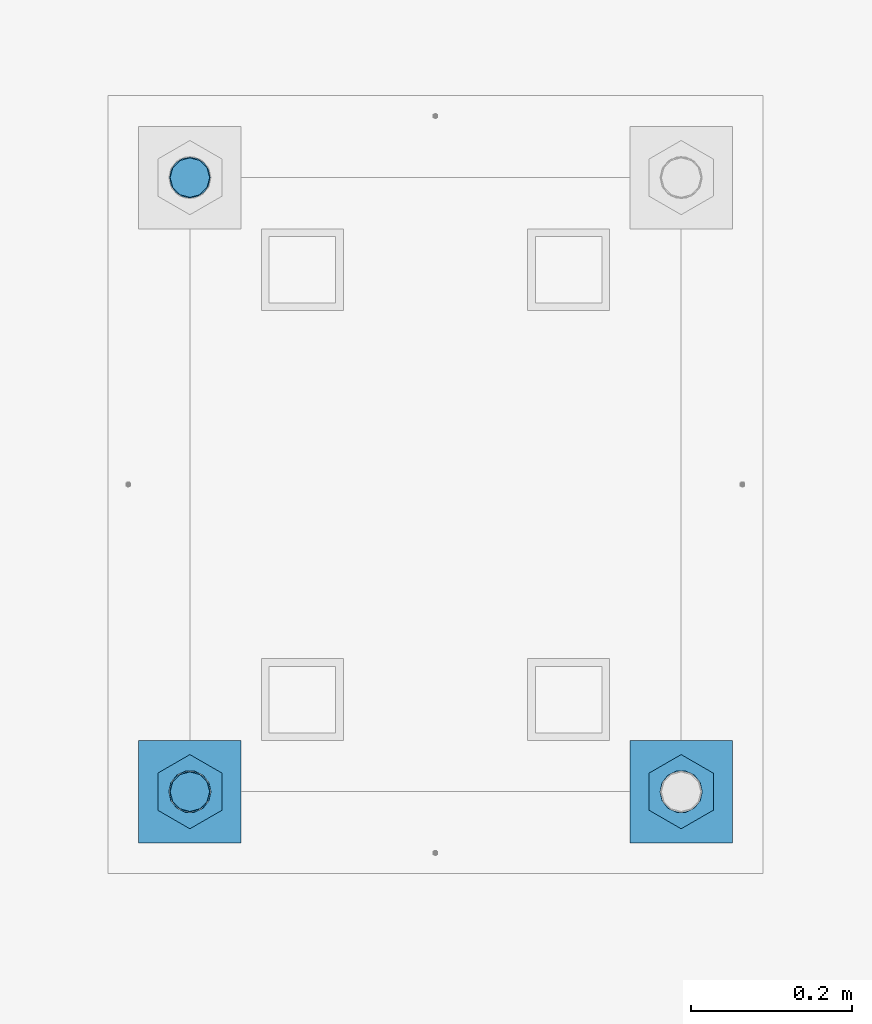
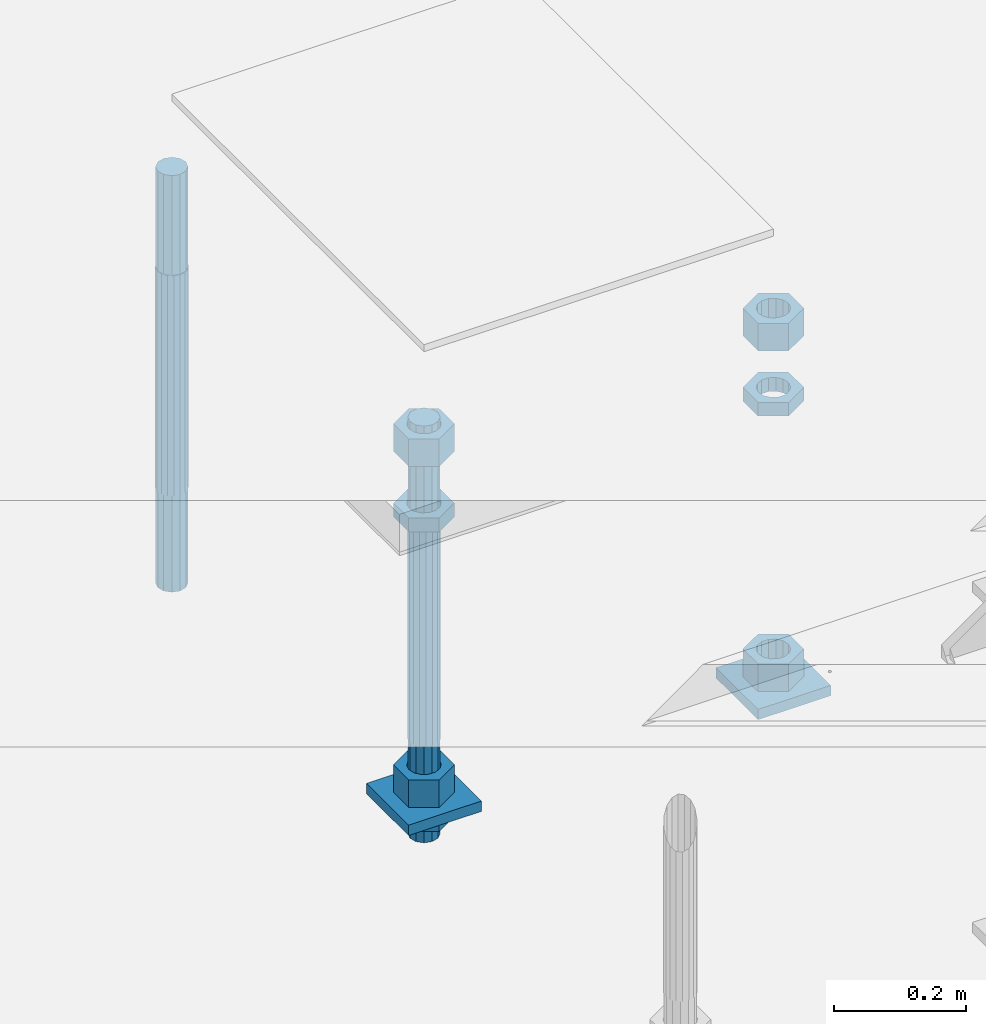
# One storey, part 2618 of 3843: 11 beams, 1 element without a shape of its own.
"""IFC2X3 building model written with IfcOpenShell, lengths in millimetres."""

from ifc_helpers import new_model, si_unit, frame, origin_with_axes, place, context, subcontext, project, spatial, faceted_brep, material, type_object, element, aggregate, save


model = new_model("IFC2X3")

# Units and contexts
model_context = context("Model", 3, precision=1e-05, world=origin_with_axes())
body_context = subcontext(model_context, "Body", "Model", "MODEL_VIEW")
ifc_project = project(units=[si_unit("LENGTHUNIT", "METRE", prefix="MILLI"), si_unit("AREAUNIT", "SQUARE_METRE"), si_unit("VOLUMEUNIT", "CUBIC_METRE"), si_unit("MASSUNIT", "GRAM", prefix="KILO"), si_unit("TIMEUNIT", "SECOND"), si_unit("PLANEANGLEUNIT", "RADIAN"), si_unit("SOLIDANGLEUNIT", "STERADIAN"), si_unit("THERMODYNAMICTEMPERATUREUNIT", "DEGREE_CELSIUS"), si_unit("LUMINOUSINTENSITYUNIT", "LUMEN")], contexts=[model_context])

# Site, building, storey
site_placement = place(None, origin_with_axes())
site = spatial("IfcSite", under=ifc_project, at=site_placement, CompositionType="ELEMENT")
building_placement = place(site_placement, origin_with_axes())
building = spatial("IfcBuilding", under=site, at=building_placement, Name="Undefined", CompositionType="ELEMENT")
storey_placement = place(building_placement, origin_with_axes())
storey = spatial("IfcBuildingStorey", under=building, at=storey_placement, Name="Undefined", CompositionType="ELEMENT", Elevation=0.0)

# Assembly, beams
assembly_placement = place(storey_placement, origin_with_axes())
assembly = element("IfcElementAssembly", 1, at=assembly_placement, inside=storey, Name="TEMPLATE", AssemblyPlace="NOTDEFINED", PredefinedType="RIGID_FRAME")
ifc_material_1 = material(Name="STEEL/A36")
beam_type_1 = type_object("IfcBeamType", PredefinedType="NOTDEFINED")
beam_1_placement = place(assembly_placement, frame((111798.099998474, 2806.70000000001, 29244.925), z_axis=(0.0, 1.0, 0.0), x_axis=(-1.0, 0.0, 0.0)))
beam_1 = element("IfcBeam", 2, at=beam_1_placement, type_object=beam_type_1, material=ifc_material_1, Name="WASHER_PLATE", context=body_context, shape_type="Brep", body=[
    faceted_brep([(0.0, 9.52500000000146, -63.5), (0.0, 9.52500000000146, 63.5), (127.0, 9.52500000000146, 63.5), (127.0, 9.52500000000146, -63.5), (0.0, -9.52500000000146, 63.5), (127.0, -9.52500000000146, 63.5), (0.0, -9.52500000000146, -63.5), (127.0, -9.52500000000146, -63.5)], [[[0, 1, 2, 3]], [[1, 4, 5, 2]], [[4, 6, 7, 5]], [[6, 0, 3, 7]], [[5, 7, 3, 2]], [[6, 4, 1, 0]]]),
])
beam_2_placement = place(assembly_placement, frame((112407.7, 2806.70000000001, 29244.925), z_axis=(0.0, 1.0, 0.0), x_axis=(-1.0, 0.0, 0.0)))
beam_2 = element("IfcBeam", 3, at=beam_2_placement, type_object=beam_type_1, material=ifc_material_1, Name="WASHER_PLATE", context=body_context, shape_type="Brep", body=[
    faceted_brep([(0.0, 9.52500000000146, -63.5), (0.0, 9.52500000000146, 63.5), (127.0, 9.52500000000146, 63.5), (127.0, 9.52500000000146, -63.5), (0.0, -9.52500000000146, 63.5), (127.0, -9.52500000000146, 63.5), (0.0, -9.52500000000146, -63.5), (127.0, -9.52500000000146, -63.5)], [[[0, 1, 2, 3]], [[1, 4, 5, 2]], [[4, 6, 7, 5]], [[6, 0, 3, 7]], [[5, 7, 3, 2]], [[6, 4, 1, 0]]]),
])
beam_type_2 = type_object("IfcBeamType", Name="2_HALF_NUT", PredefinedType="NOTDEFINED")
beam_3_placement = place(assembly_placement, frame((111734.599998474, 2806.70000000001, 29787.85), z_axis=(-1.0, 0.0, 0.0), x_axis=(0.0, 0.0, -1.0)))
beam_3 = element("IfcBeam", 4, at=beam_3_placement, type_object=beam_type_2, material=ifc_material_1, Name="NUT", ObjectType="2_HALF_NUT", context=body_context, shape_type="Brep", body=[
    faceted_brep([(0.0, -46.0369987487793, 0.0), (0.0, -23.0184993743896, -39.869213104248), (25.4000000000015, -23.0184993743896, -39.869213104248), (25.4000000000015, -46.0369987487793, 0.0), (0.0, 23.0184993743896, -39.869213104248), (25.4000000000015, 23.0184993743896, -39.869213104248), (0.0, 46.0369987487793, 0.0), (25.4000000000015, 46.0369987487793, 0.0), (0.0, 23.0184993743896, 39.869213104248), (25.4000000000015, 23.0184993743896, 39.869213104248), (0.0, -23.0184993743896, 39.869213104248), (25.4000000000015, -23.0184993743896, 39.869213104248), (0.0, 0.0, 26.1940002441406), (0.0, 11.3650617044477, 23.5999013092805), (25.4000000000015, 11.3650617044477, 23.5999013092805), (25.4000000000015, 0.0, 26.1940002441406), (0.0, 20.4791109456419, 16.3316083006721), (25.4000000000015, 20.4791109456419, 16.3316083006721), (0.0, 25.5370200498292, 5.82867859874386), (25.4000000000015, 25.5370200498292, 5.82867859874386), (0.0, 25.5370200498292, -5.82867859874386), (25.4000000000015, 25.5370200498292, -5.82867859874386), (0.0, 20.4791109456419, -16.3316083006721), (25.4000000000015, 20.4791109456419, -16.3316083006721), (0.0, 11.3650617044477, -23.5999013092805), (25.4000000000015, 11.3650617044477, -23.5999013092805), (0.0, 0.0, -26.1940002441406), (25.4000000000015, 0.0, -26.1940002441406), (0.0, -11.3650617044477, -23.5999013092805), (25.4000000000015, -11.3650617044477, -23.5999013092805), (0.0, -20.4791109456419, -16.3316083006721), (25.4000000000015, -20.4791109456419, -16.3316083006721), (0.0, -25.5370200498292, -5.82867859874386), (25.4000000000015, -25.5370200498292, -5.82867859874386), (0.0, -25.5370200498292, 5.82867859874386), (25.4000000000015, -25.5370200498292, 5.82867859874386), (0.0, -20.4791109456419, 16.3316083006721), (25.4000000000015, -20.4791109456419, 16.3316083006721), (0.0, -11.3650617044477, 23.5999013092805), (25.4000000000015, -11.3650617044477, 23.5999013092805)], [[[0, 1, 2, 3]], [[1, 4, 5, 2]], [[4, 6, 7, 5]], [[6, 8, 9, 7]], [[8, 10, 11, 9]], [[10, 0, 3, 11]], [[12, 13, 14, 15]], [[13, 16, 17, 14]], [[16, 18, 19, 17]], [[18, 20, 21, 19]], [[20, 22, 23, 21]], [[22, 24, 25, 23]], [[24, 26, 27, 25]], [[26, 28, 29, 27]], [[28, 30, 31, 29]], [[30, 32, 33, 31]], [[32, 34, 35, 33]], [[34, 36, 37, 35]], [[36, 38, 39, 37]], [[38, 12, 15, 39]], [[5, 7, 9, 11, 3, 2], [17, 19, 21, 23, 25, 27, 29, 31, 33, 35, 37, 39, 15, 14]], [[10, 8, 6, 4, 1, 0], [38, 36, 34, 32, 30, 28, 26, 24, 22, 20, 18, 16, 13, 12]]]),
])
beam_4_placement = place(assembly_placement, frame((111734.599998474, 2806.7, 29235.4), z_axis=(-1.0, 0.0, 0.0), x_axis=(0.0, 0.0, -1.0)))
beam_4 = element("IfcBeam", 5, at=beam_4_placement, type_object=beam_type_2, material=ifc_material_1, Name="NUT", ObjectType="2_HALF_NUT", context=body_context, shape_type="Brep", body=[
    faceted_brep([(0.0, -46.0369987487793, 0.0), (0.0, -23.0184993743896, -39.869213104248), (25.4000000000015, -23.0184993743896, -39.869213104248), (25.4000000000015, -46.0369987487793, 0.0), (0.0, 23.0184993743896, -39.869213104248), (25.4000000000015, 23.0184993743896, -39.869213104248), (0.0, 46.0369987487793, 0.0), (25.4000000000015, 46.0369987487793, 0.0), (0.0, 23.0184993743896, 39.869213104248), (25.4000000000015, 23.0184993743896, 39.869213104248), (0.0, -23.0184993743896, 39.869213104248), (25.4000000000015, -23.0184993743896, 39.869213104248), (0.0, 0.0, 26.1940002441406), (0.0, 11.3650617044477, 23.5999013092805), (25.4000000000015, 11.3650617044477, 23.5999013092805), (25.4000000000015, 0.0, 26.1940002441406), (0.0, 20.4791109456419, 16.3316083006721), (25.4000000000015, 20.4791109456419, 16.3316083006721), (0.0, 25.5370200498292, 5.82867859874386), (25.4000000000015, 25.5370200498292, 5.82867859874386), (0.0, 25.5370200498292, -5.82867859874386), (25.4000000000015, 25.5370200498292, -5.82867859874386), (0.0, 20.4791109456419, -16.3316083006721), (25.4000000000015, 20.4791109456419, -16.3316083006721), (0.0, 11.3650617044477, -23.5999013092805), (25.4000000000015, 11.3650617044477, -23.5999013092805), (0.0, 0.0, -26.1940002441406), (25.4000000000015, 0.0, -26.1940002441406), (0.0, -11.3650617044477, -23.5999013092805), (25.4000000000015, -11.3650617044477, -23.5999013092805), (0.0, -20.4791109456419, -16.3316083006721), (25.4000000000015, -20.4791109456419, -16.3316083006721), (0.0, -25.5370200498292, -5.82867859874386), (25.4000000000015, -25.5370200498292, -5.82867859874386), (0.0, -25.5370200498292, 5.82867859874386), (25.4000000000015, -25.5370200498292, 5.82867859874386), (0.0, -20.4791109456419, 16.3316083006721), (25.4000000000015, -20.4791109456419, 16.3316083006721), (0.0, -11.3650617044477, 23.5999013092805), (25.4000000000015, -11.3650617044477, 23.5999013092805)], [[[0, 1, 2, 3]], [[1, 4, 5, 2]], [[4, 6, 7, 5]], [[6, 8, 9, 7]], [[8, 10, 11, 9]], [[10, 0, 3, 11]], [[12, 13, 14, 15]], [[13, 16, 17, 14]], [[16, 18, 19, 17]], [[18, 20, 21, 19]], [[20, 22, 23, 21]], [[22, 24, 25, 23]], [[24, 26, 27, 25]], [[26, 28, 29, 27]], [[28, 30, 31, 29]], [[30, 32, 33, 31]], [[32, 34, 35, 33]], [[34, 36, 37, 35]], [[36, 38, 39, 37]], [[38, 12, 15, 39]], [[5, 7, 9, 11, 3, 2], [17, 19, 21, 23, 25, 27, 29, 31, 33, 35, 37, 39, 15, 14]], [[10, 8, 6, 4, 1, 0], [38, 36, 34, 32, 30, 28, 26, 24, 22, 20, 18, 16, 13, 12]]]),
])
beam_5_placement = place(assembly_placement, frame((112344.2, 2806.70000000001, 29787.85), z_axis=(-1.0, 0.0, 0.0), x_axis=(0.0, 0.0, -1.0)))
beam_5 = element("IfcBeam", 6, at=beam_5_placement, type_object=beam_type_2, material=ifc_material_1, Name="NUT", ObjectType="2_HALF_NUT", context=body_context, shape_type="Brep", body=[
    faceted_brep([(0.0, -46.0369987487793, 0.0), (0.0, -23.0184993743896, -39.869213104248), (25.4000000000015, -23.0184993743896, -39.869213104248), (25.4000000000015, -46.0369987487793, 0.0), (0.0, 23.0184993743896, -39.869213104248), (25.4000000000015, 23.0184993743896, -39.869213104248), (0.0, 46.0369987487793, 0.0), (25.4000000000015, 46.0369987487793, 0.0), (0.0, 23.0184993743896, 39.869213104248), (25.4000000000015, 23.0184993743896, 39.869213104248), (0.0, -23.0184993743896, 39.869213104248), (25.4000000000015, -23.0184993743896, 39.869213104248), (0.0, 0.0, 26.1940002441406), (0.0, 11.3650617044477, 23.5999013092805), (25.4000000000015, 11.3650617044477, 23.5999013092805), (25.4000000000015, 0.0, 26.1940002441406), (0.0, 20.4791109456419, 16.3316083006721), (25.4000000000015, 20.4791109456419, 16.3316083006721), (0.0, 25.5370200498292, 5.82867859874386), (25.4000000000015, 25.5370200498292, 5.82867859874386), (0.0, 25.5370200498292, -5.82867859874386), (25.4000000000015, 25.5370200498292, -5.82867859874386), (0.0, 20.4791109456419, -16.3316083006721), (25.4000000000015, 20.4791109456419, -16.3316083006721), (0.0, 11.3650617044477, -23.5999013092805), (25.4000000000015, 11.3650617044477, -23.5999013092805), (0.0, 0.0, -26.1940002441406), (25.4000000000015, 0.0, -26.1940002441406), (0.0, -11.3650617044477, -23.5999013092805), (25.4000000000015, -11.3650617044477, -23.5999013092805), (0.0, -20.4791109456419, -16.3316083006721), (25.4000000000015, -20.4791109456419, -16.3316083006721), (0.0, -25.5370200498292, -5.82867859874386), (25.4000000000015, -25.5370200498292, -5.82867859874386), (0.0, -25.5370200498292, 5.82867859874386), (25.4000000000015, -25.5370200498292, 5.82867859874386), (0.0, -20.4791109456419, 16.3316083006721), (25.4000000000015, -20.4791109456419, 16.3316083006721), (0.0, -11.3650617044477, 23.5999013092805), (25.4000000000015, -11.3650617044477, 23.5999013092805)], [[[0, 1, 2, 3]], [[1, 4, 5, 2]], [[4, 6, 7, 5]], [[6, 8, 9, 7]], [[8, 10, 11, 9]], [[10, 0, 3, 11]], [[12, 13, 14, 15]], [[13, 16, 17, 14]], [[16, 18, 19, 17]], [[18, 20, 21, 19]], [[20, 22, 23, 21]], [[22, 24, 25, 23]], [[24, 26, 27, 25]], [[26, 28, 29, 27]], [[28, 30, 31, 29]], [[30, 32, 33, 31]], [[32, 34, 35, 33]], [[34, 36, 37, 35]], [[36, 38, 39, 37]], [[38, 12, 15, 39]], [[5, 7, 9, 11, 3, 2], [17, 19, 21, 23, 25, 27, 29, 31, 33, 35, 37, 39, 15, 14]], [[10, 8, 6, 4, 1, 0], [38, 36, 34, 32, 30, 28, 26, 24, 22, 20, 18, 16, 13, 12]]]),
])
beam_type_3 = type_object("IfcBeamType", Name="2_HEAVY_HEX_NUT", PredefinedType="NOTDEFINED")
beam_6_placement = place(assembly_placement, frame((111734.599998474, 2806.70000000001, 29933.9), z_axis=(-1.0, 0.0, 0.0), x_axis=(0.0, 0.0, -1.0)))
beam_6 = element("IfcBeam", 7, at=beam_6_placement, type_object=beam_type_3, material=ifc_material_1, Name="NUT", ObjectType="2_HEAVY_HEX_NUT", context=body_context, shape_type="Brep", body=[
    faceted_brep([(0.0, -46.0369987487793, 0.0), (0.0, -23.0184993743896, -39.869213104248), (50.7999999999993, -23.0184993743896, -39.869213104248), (50.7999999999993, -46.0369987487793, 0.0), (0.0, 23.0184993743896, -39.869213104248), (50.7999999999993, 23.0184993743896, -39.869213104248), (0.0, 46.0369987487793, 0.0), (50.7999999999993, 46.0369987487793, 0.0), (0.0, 23.0184993743896, 39.869213104248), (50.7999999999993, 23.0184993743896, 39.869213104248), (0.0, -23.0184993743896, 39.869213104248), (50.7999999999993, -23.0184993743896, 39.869213104248), (0.0, 0.0, 26.1940002441406), (0.0, 11.3650617044477, 23.5999013092805), (50.7999999999993, 11.3650617044477, 23.5999013092805), (50.7999999999993, 0.0, 26.1940002441406), (0.0, 20.4791109456419, 16.3316083006721), (50.7999999999993, 20.4791109456419, 16.3316083006721), (0.0, 25.5370200498292, 5.82867859874386), (50.7999999999993, 25.5370200498292, 5.82867859874386), (0.0, 25.5370200498292, -5.82867859874386), (50.7999999999993, 25.5370200498292, -5.82867859874386), (0.0, 20.4791109456419, -16.3316083006721), (50.7999999999993, 20.4791109456419, -16.3316083006721), (0.0, 11.3650617044477, -23.5999013092805), (50.7999999999993, 11.3650617044477, -23.5999013092805), (0.0, 0.0, -26.1940002441406), (50.7999999999993, 0.0, -26.1940002441406), (0.0, -11.3650617044477, -23.5999013092805), (50.7999999999993, -11.3650617044477, -23.5999013092805), (0.0, -20.4791109456419, -16.3316083006721), (50.7999999999993, -20.4791109456419, -16.3316083006721), (0.0, -25.5370200498292, -5.82867859874386), (50.7999999999993, -25.5370200498292, -5.82867859874386), (0.0, -25.5370200498292, 5.82867859874386), (50.7999999999993, -25.5370200498292, 5.82867859874386), (0.0, -20.4791109456419, 16.3316083006721), (50.7999999999993, -20.4791109456419, 16.3316083006721), (0.0, -11.3650617044477, 23.5999013092805), (50.7999999999993, -11.3650617044477, 23.5999013092805)], [[[0, 1, 2, 3]], [[1, 4, 5, 2]], [[4, 6, 7, 5]], [[6, 8, 9, 7]], [[8, 10, 11, 9]], [[10, 0, 3, 11]], [[12, 13, 14, 15]], [[13, 16, 17, 14]], [[16, 18, 19, 17]], [[18, 20, 21, 19]], [[20, 22, 23, 21]], [[22, 24, 25, 23]], [[24, 26, 27, 25]], [[26, 28, 29, 27]], [[28, 30, 31, 29]], [[30, 32, 33, 31]], [[32, 34, 35, 33]], [[34, 36, 37, 35]], [[36, 38, 39, 37]], [[38, 12, 15, 39]], [[5, 7, 9, 11, 3, 2], [17, 19, 21, 23, 25, 27, 29, 31, 33, 35, 37, 39, 15, 14]], [[10, 8, 6, 4, 1, 0], [38, 36, 34, 32, 30, 28, 26, 24, 22, 20, 18, 16, 13, 12]]]),
])
beam_7_placement = place(assembly_placement, frame((111734.599998474, 2806.70000000001, 29305.25), z_axis=(-1.0, 0.0, 0.0), x_axis=(0.0, 0.0, -1.0)))
beam_7 = element("IfcBeam", 8, at=beam_7_placement, type_object=beam_type_3, material=ifc_material_1, Name="NUT", ObjectType="2_HEAVY_HEX_NUT", context=body_context, shape_type="Brep", body=[
    faceted_brep([(0.0, -46.0369987487793, 0.0), (0.0, -23.0184993743896, -39.869213104248), (50.7999999999993, -23.0184993743896, -39.869213104248), (50.7999999999993, -46.0369987487793, 0.0), (0.0, 23.0184993743896, -39.869213104248), (50.7999999999993, 23.0184993743896, -39.869213104248), (0.0, 46.0369987487793, 0.0), (50.7999999999993, 46.0369987487793, 0.0), (0.0, 23.0184993743896, 39.869213104248), (50.7999999999993, 23.0184993743896, 39.869213104248), (0.0, -23.0184993743896, 39.869213104248), (50.7999999999993, -23.0184993743896, 39.869213104248), (0.0, 0.0, 26.1940002441406), (0.0, 11.3650617044477, 23.5999013092805), (50.7999999999993, 11.3650617044477, 23.5999013092805), (50.7999999999993, 0.0, 26.1940002441406), (0.0, 20.4791109456419, 16.3316083006721), (50.7999999999993, 20.4791109456419, 16.3316083006721), (0.0, 25.5370200498292, 5.82867859874386), (50.7999999999993, 25.5370200498292, 5.82867859874386), (0.0, 25.5370200498292, -5.82867859874386), (50.7999999999993, 25.5370200498292, -5.82867859874386), (0.0, 20.4791109456419, -16.3316083006721), (50.7999999999993, 20.4791109456419, -16.3316083006721), (0.0, 11.3650617044477, -23.5999013092805), (50.7999999999993, 11.3650617044477, -23.5999013092805), (0.0, 0.0, -26.1940002441406), (50.7999999999993, 0.0, -26.1940002441406), (0.0, -11.3650617044477, -23.5999013092805), (50.7999999999993, -11.3650617044477, -23.5999013092805), (0.0, -20.4791109456419, -16.3316083006721), (50.7999999999993, -20.4791109456419, -16.3316083006721), (0.0, -25.5370200498292, -5.82867859874386), (50.7999999999993, -25.5370200498292, -5.82867859874386), (0.0, -25.5370200498292, 5.82867859874386), (50.7999999999993, -25.5370200498292, 5.82867859874386), (0.0, -20.4791109456419, 16.3316083006721), (50.7999999999993, -20.4791109456419, 16.3316083006721), (0.0, -11.3650617044477, 23.5999013092805), (50.7999999999993, -11.3650617044477, 23.5999013092805)], [[[0, 1, 2, 3]], [[1, 4, 5, 2]], [[4, 6, 7, 5]], [[6, 8, 9, 7]], [[8, 10, 11, 9]], [[10, 0, 3, 11]], [[12, 13, 14, 15]], [[13, 16, 17, 14]], [[16, 18, 19, 17]], [[18, 20, 21, 19]], [[20, 22, 23, 21]], [[22, 24, 25, 23]], [[24, 26, 27, 25]], [[26, 28, 29, 27]], [[28, 30, 31, 29]], [[30, 32, 33, 31]], [[32, 34, 35, 33]], [[34, 36, 37, 35]], [[36, 38, 39, 37]], [[38, 12, 15, 39]], [[5, 7, 9, 11, 3, 2], [17, 19, 21, 23, 25, 27, 29, 31, 33, 35, 37, 39, 15, 14]], [[10, 8, 6, 4, 1, 0], [38, 36, 34, 32, 30, 28, 26, 24, 22, 20, 18, 16, 13, 12]]]),
])
beam_8_placement = place(assembly_placement, frame((112344.2, 2806.70000000001, 29933.9), z_axis=(-1.0, 0.0, 0.0), x_axis=(0.0, 0.0, -1.0)))
beam_8 = element("IfcBeam", 9, at=beam_8_placement, type_object=beam_type_3, material=ifc_material_1, Name="NUT", ObjectType="2_HEAVY_HEX_NUT", context=body_context, shape_type="Brep", body=[
    faceted_brep([(0.0, -46.0369987487793, 0.0), (0.0, -23.0184993743896, -39.869213104248), (50.7999999999993, -23.0184993743896, -39.869213104248), (50.7999999999993, -46.0369987487793, 0.0), (0.0, 23.0184993743896, -39.869213104248), (50.7999999999993, 23.0184993743896, -39.869213104248), (0.0, 46.0369987487793, 0.0), (50.7999999999993, 46.0369987487793, 0.0), (0.0, 23.0184993743896, 39.869213104248), (50.7999999999993, 23.0184993743896, 39.869213104248), (0.0, -23.0184993743896, 39.869213104248), (50.7999999999993, -23.0184993743896, 39.869213104248), (0.0, 0.0, 26.1940002441406), (0.0, 11.3650617044477, 23.5999013092805), (50.7999999999993, 11.3650617044477, 23.5999013092805), (50.7999999999993, 0.0, 26.1940002441406), (0.0, 20.4791109456419, 16.3316083006721), (50.7999999999993, 20.4791109456419, 16.3316083006721), (0.0, 25.5370200498292, 5.82867859874386), (50.7999999999993, 25.5370200498292, 5.82867859874386), (0.0, 25.5370200498292, -5.82867859874386), (50.7999999999993, 25.5370200498292, -5.82867859874386), (0.0, 20.4791109456419, -16.3316083006721), (50.7999999999993, 20.4791109456419, -16.3316083006721), (0.0, 11.3650617044477, -23.5999013092805), (50.7999999999993, 11.3650617044477, -23.5999013092805), (0.0, 0.0, -26.1940002441406), (50.7999999999993, 0.0, -26.1940002441406), (0.0, -11.3650617044477, -23.5999013092805), (50.7999999999993, -11.3650617044477, -23.5999013092805), (0.0, -20.4791109456419, -16.3316083006721), (50.7999999999993, -20.4791109456419, -16.3316083006721), (0.0, -25.5370200498292, -5.82867859874386), (50.7999999999993, -25.5370200498292, -5.82867859874386), (0.0, -25.5370200498292, 5.82867859874386), (50.7999999999993, -25.5370200498292, 5.82867859874386), (0.0, -20.4791109456419, 16.3316083006721), (50.7999999999993, -20.4791109456419, 16.3316083006721), (0.0, -11.3650617044477, 23.5999013092805), (50.7999999999993, -11.3650617044477, 23.5999013092805)], [[[0, 1, 2, 3]], [[1, 4, 5, 2]], [[4, 6, 7, 5]], [[6, 8, 9, 7]], [[8, 10, 11, 9]], [[10, 0, 3, 11]], [[12, 13, 14, 15]], [[13, 16, 17, 14]], [[16, 18, 19, 17]], [[18, 20, 21, 19]], [[20, 22, 23, 21]], [[22, 24, 25, 23]], [[24, 26, 27, 25]], [[26, 28, 29, 27]], [[28, 30, 31, 29]], [[30, 32, 33, 31]], [[32, 34, 35, 33]], [[34, 36, 37, 35]], [[36, 38, 39, 37]], [[38, 12, 15, 39]], [[5, 7, 9, 11, 3, 2], [17, 19, 21, 23, 25, 27, 29, 31, 33, 35, 37, 39, 15, 14]], [[10, 8, 6, 4, 1, 0], [38, 36, 34, 32, 30, 28, 26, 24, 22, 20, 18, 16, 13, 12]]]),
])
beam_9_placement = place(assembly_placement, frame((112344.2, 2806.70000000001, 29305.25), z_axis=(-1.0, 0.0, 0.0), x_axis=(0.0, 0.0, -1.0)))
beam_9 = element("IfcBeam", 10, at=beam_9_placement, type_object=beam_type_3, material=ifc_material_1, Name="NUT", ObjectType="2_HEAVY_HEX_NUT", context=body_context, shape_type="Brep", body=[
    faceted_brep([(0.0, -46.0369987487793, 0.0), (0.0, -23.0184993743896, -39.869213104248), (50.7999999999993, -23.0184993743896, -39.869213104248), (50.7999999999993, -46.0369987487793, 0.0), (0.0, 23.0184993743896, -39.869213104248), (50.7999999999993, 23.0184993743896, -39.869213104248), (0.0, 46.0369987487793, 0.0), (50.7999999999993, 46.0369987487793, 0.0), (0.0, 23.0184993743896, 39.869213104248), (50.7999999999993, 23.0184993743896, 39.869213104248), (0.0, -23.0184993743896, 39.869213104248), (50.7999999999993, -23.0184993743896, 39.869213104248), (0.0, 0.0, 26.1940002441406), (0.0, 11.3650617044477, 23.5999013092805), (50.7999999999993, 11.3650617044477, 23.5999013092805), (50.7999999999993, 0.0, 26.1940002441406), (0.0, 20.4791109456419, 16.3316083006721), (50.7999999999993, 20.4791109456419, 16.3316083006721), (0.0, 25.5370200498292, 5.82867859874386), (50.7999999999993, 25.5370200498292, 5.82867859874386), (0.0, 25.5370200498292, -5.82867859874386), (50.7999999999993, 25.5370200498292, -5.82867859874386), (0.0, 20.4791109456419, -16.3316083006721), (50.7999999999993, 20.4791109456419, -16.3316083006721), (0.0, 11.3650617044477, -23.5999013092805), (50.7999999999993, 11.3650617044477, -23.5999013092805), (0.0, 0.0, -26.1940002441406), (50.7999999999993, 0.0, -26.1940002441406), (0.0, -11.3650617044477, -23.5999013092805), (50.7999999999993, -11.3650617044477, -23.5999013092805), (0.0, -20.4791109456419, -16.3316083006721), (50.7999999999993, -20.4791109456419, -16.3316083006721), (0.0, -25.5370200498292, -5.82867859874386), (50.7999999999993, -25.5370200498292, -5.82867859874386), (0.0, -25.5370200498292, 5.82867859874386), (50.7999999999993, -25.5370200498292, 5.82867859874386), (0.0, -20.4791109456419, 16.3316083006721), (50.7999999999993, -20.4791109456419, 16.3316083006721), (0.0, -11.3650617044477, 23.5999013092805), (50.7999999999993, -11.3650617044477, 23.5999013092805)], [[[0, 1, 2, 3]], [[1, 4, 5, 2]], [[4, 6, 7, 5]], [[6, 8, 9, 7]], [[8, 10, 11, 9]], [[10, 0, 3, 11]], [[12, 13, 14, 15]], [[13, 16, 17, 14]], [[16, 18, 19, 17]], [[18, 20, 21, 19]], [[20, 22, 23, 21]], [[22, 24, 25, 23]], [[24, 26, 27, 25]], [[26, 28, 29, 27]], [[28, 30, 31, 29]], [[30, 32, 33, 31]], [[32, 34, 35, 33]], [[34, 36, 37, 35]], [[36, 38, 39, 37]], [[38, 12, 15, 39]], [[5, 7, 9, 11, 3, 2], [17, 19, 21, 23, 25, 27, 29, 31, 33, 35, 37, 39, 15, 14]], [[10, 8, 6, 4, 1, 0], [38, 36, 34, 32, 30, 28, 26, 24, 22, 20, 18, 16, 13, 12]]]),
])
ifc_material_2 = material()
beam_type_4 = type_object("IfcBeamType", PredefinedType="NOTDEFINED")
beam_10_placement = place(assembly_placement, frame((111734.599998474, 3568.70000000001, 29762.45), z_axis=(-1.0, 0.0, 0.0), x_axis=(0.0, 0.0, -1.0)))
beam_10 = element("IfcBeam", 11, at=beam_10_placement, type_object=beam_type_4, material=ifc_material_2, Name="ANCHOR_ROD", context=body_context, shape_type="Brep", body=[
    faceted_brep([(-184.150000000001, -21.217622392709, 12.25), (-184.150000000001, -12.2499999999854, 21.2176223927163), (-184.150000000001, 1.45519152283669e-11, 24.5), (-184.150000000001, 12.2500000000146, 21.2176223927163), (-184.150000000001, 21.2176223927381, 12.25), (-184.150000000001, 24.5000000000146, 0.0), (-184.150000000001, 21.2176223927381, -12.25), (-184.150000000001, 12.2500000000146, -21.2176223927163), (-184.150000000001, 1.45519152283669e-11, -24.5), (-184.150000000001, -12.2499999999854, -21.2176223927163), (-184.150000000001, -21.217622392709, -12.25), (-184.150000000001, -24.4999999999854, 0.0), (0.0, 24.5000000000146, 0.0), (0.0, 21.2176223927381, -12.25), (0.0, 12.2500000000146, -21.2176223927163), (0.0, 1.45519152283669e-11, -24.5), (0.0, -12.2499999999854, -21.2176223927163), (0.0, -21.217622392709, -12.25), (0.0, -24.4999999999854, 0.0), (0.0, -21.217622392709, 12.25), (0.0, -12.2499999999854, 21.2176223927163), (0.0, 1.45519152283669e-11, 24.5), (0.0, 12.2500000000146, 21.2176223927163), (0.0, 21.2176223927381, 12.25), (0.0, -23.4665401257807, 9.72015918207035), (0.0, -17.9605122421344, 17.9605122421417), (0.0, -9.72015918207762, 23.466540125788), (0.0, 0.0, 25.4000000000015), (0.0, 9.72015918207762, 23.466540125788), (0.0, 17.9605122421344, 17.9605122421417), (0.0, 23.4665401257807, 9.72015918207035), (0.0, 25.3999996185303, 0.0), (0.0, 23.4665401257807, -9.72015918207035), (0.0, 17.9605122421344, -17.9605122421417), (0.0, 9.72015918207762, -23.466540125788), (0.0, 0.0, -25.4000000000015), (0.0, -9.72015918207762, -23.466540125788), (0.0, -17.9605122421344, -17.9605122421417), (0.0, -23.4665401257807, -9.72015918207035), (0.0, -25.3999996185303, 0.0), (406.399999999998, -25.3999999999942, 0.0), (406.399999999998, -23.4665401257807, 9.72015918207035), (406.399999999998, -17.9605122421344, 17.9605122421417), (406.399999999998, -9.72015918207762, 23.466540125788), (406.399999999998, 0.0, 25.4000000000015), (406.399999999998, 9.72015918207762, 23.466540125788), (406.399999999998, 17.9605122421344, 17.9605122421417), (406.399999999998, 23.4665401257807, 9.72015918207035), (406.399999999998, 25.3999999999942, 0.0), (406.399999999998, 23.4665401257807, -9.72015918207035), (406.399999999998, 17.9605122421344, -17.9605122421417), (406.399999999998, 9.72015918207762, -23.466540125788), (406.399999999998, 0.0, -25.4000000000015), (406.399999999998, -9.72015918207762, -23.466540125788), (406.399999999998, -17.9605122421344, -17.9605122421417), (406.399999999998, -23.4665401257807, -9.72015918207035), (406.399999999998, -12.2499999999854, 21.2176223927163), (406.399999999998, 1.45519152283669e-11, 24.5), (406.399999999998, 12.2500000000146, 21.2176223927163), (406.399999999998, 21.2176223927381, 12.25), (406.399999999998, 24.5000000000146, 0.0), (406.399999999998, 21.2176223927381, -12.25), (406.399999999998, 12.2500000000146, -21.2176223927163), (406.399999999998, 1.45519152283669e-11, -24.5), (406.399999999998, -12.2499999999854, -21.2176223927163), (406.399999999998, -21.217622392709, -12.25), (406.399999999998, -24.4999999999854, 0.0), (406.399999999998, -21.217622392709, 12.25), (584.200000000001, -12.2499999999854, -21.2176223927163), (584.200000000001, 1.45519152283669e-11, -24.5), (584.200000000001, 12.2500000000146, -21.2176223927163), (584.200000000001, 21.2176223927381, -12.25), (584.200000000001, 24.5000000000146, 0.0), (584.200000000001, 21.2176223927381, 12.25), (584.200000000001, 12.2500000000146, 21.2176223927163), (584.200000000001, 1.45519152283669e-11, 24.5), (584.200000000001, -12.2499999999854, 21.2176223927163), (584.200000000001, -21.217622392709, 12.25), (584.200000000001, -24.4999999999854, 0.0), (584.200000000001, -21.217622392709, -12.25)], [[[0, 1, 2, 3, 4, 5, 6, 7, 8, 9, 10, 11]], [[6, 5, 12, 13]], [[7, 6, 13, 14]], [[8, 7, 14, 15]], [[9, 8, 15, 16]], [[10, 9, 16, 17]], [[11, 10, 17, 18]], [[0, 11, 18, 19]], [[1, 0, 19, 20]], [[2, 1, 20, 21]], [[3, 2, 21, 22]], [[4, 3, 22, 23]], [[5, 4, 23, 12]], [[24, 25, 26, 27, 28, 29, 30, 31, 32, 33, 34, 35, 36, 37, 38, 39], [22, 21, 20, 19, 18, 17, 16, 15, 14, 13, 12, 23]], [[24, 39, 40, 41]], [[25, 24, 41, 42]], [[26, 25, 42, 43]], [[27, 26, 43, 44]], [[28, 27, 44, 45]], [[29, 28, 45, 46]], [[30, 29, 46, 47]], [[31, 30, 47, 48]], [[32, 31, 48, 49]], [[33, 32, 49, 50]], [[34, 33, 50, 51]], [[35, 34, 51, 52]], [[36, 35, 52, 53]], [[37, 36, 53, 54]], [[38, 37, 54, 55]], [[39, 38, 55, 40]], [[54, 53, 52, 51, 50, 49, 48, 47, 46, 45, 44, 43, 42, 41, 40, 55], [56, 57, 58, 59, 60, 61, 62, 63, 64, 65, 66, 67]], [[68, 69, 70, 71, 72, 73, 74, 75, 76, 77, 78, 79]], [[76, 75, 57, 56]], [[77, 76, 56, 67]], [[78, 77, 67, 66]], [[79, 78, 66, 65]], [[68, 79, 65, 64]], [[69, 68, 64, 63]], [[70, 69, 63, 62]], [[71, 70, 62, 61]], [[72, 71, 61, 60]], [[73, 72, 60, 59]], [[74, 73, 59, 58]], [[75, 74, 58, 57]]]),
])
beam_11_placement = place(assembly_placement, frame((111734.599998474, 2806.70000000001, 29762.45), z_axis=(-1.0, 0.0, 0.0), x_axis=(0.0, 0.0, -1.0)))
beam_11 = element("IfcBeam", 12, at=beam_11_placement, type_object=beam_type_4, material=ifc_material_2, Name="ANCHOR_ROD", context=body_context, shape_type="Brep", body=[
    faceted_brep([(-184.150000000001, -21.217622392709, 12.25), (-184.150000000001, -12.2499999999854, 21.2176223927163), (-184.150000000001, 1.45519152283669e-11, 24.5), (-184.150000000001, 12.2500000000146, 21.2176223927163), (-184.150000000001, 21.2176223927381, 12.25), (-184.150000000001, 24.5000000000146, 0.0), (-184.150000000001, 21.2176223927381, -12.25), (-184.150000000001, 12.2500000000146, -21.2176223927163), (-184.150000000001, 1.45519152283669e-11, -24.5), (-184.150000000001, -12.2499999999854, -21.2176223927163), (-184.150000000001, -21.217622392709, -12.25), (-184.150000000001, -24.4999999999854, 0.0), (0.0, 24.5000000000146, 0.0), (0.0, 21.2176223927381, -12.25), (0.0, 12.2500000000146, -21.2176223927163), (0.0, 1.45519152283669e-11, -24.5), (0.0, -12.2499999999854, -21.2176223927163), (0.0, -21.217622392709, -12.25), (0.0, -24.4999999999854, 0.0), (0.0, -21.217622392709, 12.25), (0.0, -12.2499999999854, 21.2176223927163), (0.0, 1.45519152283669e-11, 24.5), (0.0, 12.2500000000146, 21.2176223927163), (0.0, 21.2176223927381, 12.25), (0.0, -23.4665401257807, 9.72015918207035), (0.0, -17.9605122421344, 17.9605122421417), (0.0, -9.72015918207762, 23.466540125788), (0.0, 0.0, 25.4000000000015), (0.0, 9.72015918207762, 23.466540125788), (0.0, 17.9605122421344, 17.9605122421417), (0.0, 23.4665401257807, 9.72015918207035), (0.0, 25.3999996185303, 0.0), (0.0, 23.4665401257807, -9.72015918207035), (0.0, 17.9605122421344, -17.9605122421417), (0.0, 9.72015918207762, -23.466540125788), (0.0, 0.0, -25.4000000000015), (0.0, -9.72015918207762, -23.466540125788), (0.0, -17.9605122421344, -17.9605122421417), (0.0, -23.4665401257807, -9.72015918207035), (0.0, -25.3999996185303, 0.0), (406.399999999998, -25.3999999999942, 0.0), (406.399999999998, -23.4665401257807, 9.72015918207035), (406.399999999998, -17.9605122421344, 17.9605122421417), (406.399999999998, -9.72015918207762, 23.466540125788), (406.399999999998, 0.0, 25.4000000000015), (406.399999999998, 9.72015918207762, 23.466540125788), (406.399999999998, 17.9605122421344, 17.9605122421417), (406.399999999998, 23.4665401257807, 9.72015918207035), (406.399999999998, 25.3999999999942, 0.0), (406.399999999998, 23.4665401257807, -9.72015918207035), (406.399999999998, 17.9605122421344, -17.9605122421417), (406.399999999998, 9.72015918207762, -23.466540125788), (406.399999999998, 0.0, -25.4000000000015), (406.399999999998, -9.72015918207762, -23.466540125788), (406.399999999998, -17.9605122421344, -17.9605122421417), (406.399999999998, -23.4665401257807, -9.72015918207035), (406.399999999998, -12.2499999999854, 21.2176223927163), (406.399999999998, 1.45519152283669e-11, 24.5), (406.399999999998, 12.2500000000146, 21.2176223927163), (406.399999999998, 21.2176223927381, 12.25), (406.399999999998, 24.5000000000146, 0.0), (406.399999999998, 21.2176223927381, -12.25), (406.399999999998, 12.2500000000146, -21.2176223927163), (406.399999999998, 1.45519152283669e-11, -24.5), (406.399999999998, -12.2499999999854, -21.2176223927163), (406.399999999998, -21.217622392709, -12.25), (406.399999999998, -24.4999999999854, 0.0), (406.399999999998, -21.217622392709, 12.25), (584.200000000001, -12.2499999999854, -21.2176223927163), (584.200000000001, 1.45519152283669e-11, -24.5), (584.200000000001, 12.2500000000146, -21.2176223927163), (584.200000000001, 21.2176223927381, -12.25), (584.200000000001, 24.5000000000146, 0.0), (584.200000000001, 21.2176223927381, 12.25), (584.200000000001, 12.2500000000146, 21.2176223927163), (584.200000000001, 1.45519152283669e-11, 24.5), (584.200000000001, -12.2499999999854, 21.2176223927163), (584.200000000001, -21.217622392709, 12.25), (584.200000000001, -24.4999999999854, 0.0), (584.200000000001, -21.217622392709, -12.25)], [[[0, 1, 2, 3, 4, 5, 6, 7, 8, 9, 10, 11]], [[6, 5, 12, 13]], [[7, 6, 13, 14]], [[8, 7, 14, 15]], [[9, 8, 15, 16]], [[10, 9, 16, 17]], [[11, 10, 17, 18]], [[0, 11, 18, 19]], [[1, 0, 19, 20]], [[2, 1, 20, 21]], [[3, 2, 21, 22]], [[4, 3, 22, 23]], [[5, 4, 23, 12]], [[24, 25, 26, 27, 28, 29, 30, 31, 32, 33, 34, 35, 36, 37, 38, 39], [22, 21, 20, 19, 18, 17, 16, 15, 14, 13, 12, 23]], [[24, 39, 40, 41]], [[25, 24, 41, 42]], [[26, 25, 42, 43]], [[27, 26, 43, 44]], [[28, 27, 44, 45]], [[29, 28, 45, 46]], [[30, 29, 46, 47]], [[31, 30, 47, 48]], [[32, 31, 48, 49]], [[33, 32, 49, 50]], [[34, 33, 50, 51]], [[35, 34, 51, 52]], [[36, 35, 52, 53]], [[37, 36, 53, 54]], [[38, 37, 54, 55]], [[39, 38, 55, 40]], [[54, 53, 52, 51, 50, 49, 48, 47, 46, 45, 44, 43, 42, 41, 40, 55], [56, 57, 58, 59, 60, 61, 62, 63, 64, 65, 66, 67]], [[68, 69, 70, 71, 72, 73, 74, 75, 76, 77, 78, 79]], [[76, 75, 57, 56]], [[77, 76, 56, 67]], [[78, 77, 67, 66]], [[79, 78, 66, 65]], [[68, 79, 65, 64]], [[69, 68, 64, 63]], [[70, 69, 63, 62]], [[71, 70, 62, 61]], [[72, 71, 61, 60]], [[73, 72, 60, 59]], [[74, 73, 59, 58]], [[75, 74, 58, 57]]]),
])
aggregate(assembly, [beam_10, beam_1, beam_3, beam_6, beam_7, beam_4, beam_11, beam_2, beam_5, beam_8, beam_9])

save(model, "model.ifc")
